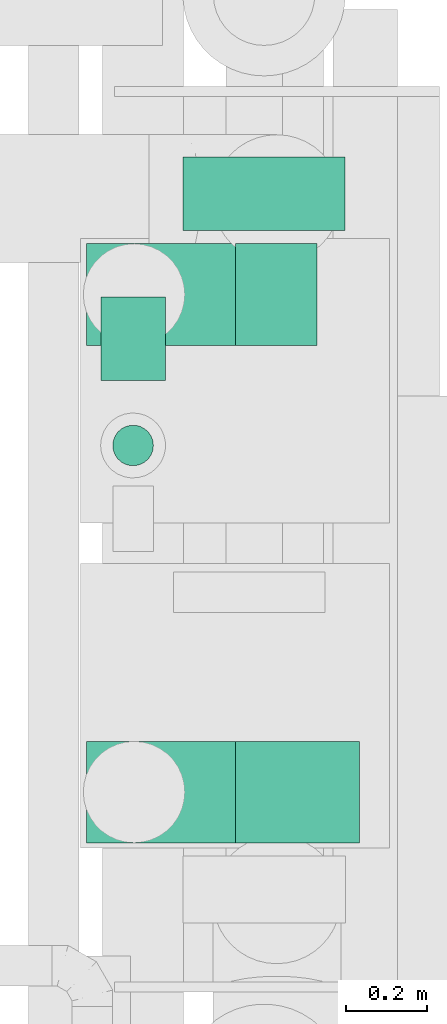
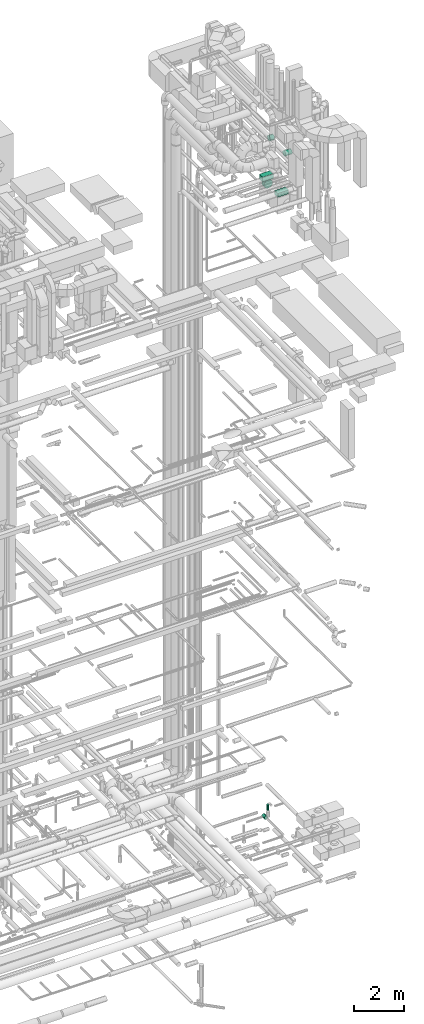
# One storey, part 310 of 337: 7 flow segments.
"""IFC2X3 building model written with IfcOpenShell, lengths in millimetres."""

from ifc_helpers import new_model, entity, si_unit, converted_unit, derived_unit, direction, frame, origin, origin_2d_with_axis, place, context, subcontext, project, spatial, rectangle, circle, extrude, type_object, element, save


model = new_model("IFC2X3")

# Units and contexts
model_context = context("Model", 3, precision=0.01, world=origin(), true_north=direction((6.12303176911189e-17, 1.0)))
body_context = subcontext(model_context, "Body", "Model", "MODEL_VIEW")
ifc_project = project(units=[si_unit("LENGTHUNIT", "METRE", prefix="MILLI"), si_unit("AREAUNIT", "SQUARE_METRE"), si_unit("VOLUMEUNIT", "CUBIC_METRE"), converted_unit("PLANEANGLEUNIT", "DEGREE", entity("IfcRatioMeasure", 0.0174532925199433), si_unit("PLANEANGLEUNIT", "RADIAN"), dimensions=[0, 0, 0, 0, 0, 0, 0]), si_unit("MASSUNIT", "GRAM", prefix="KILO"), derived_unit("MASSDENSITYUNIT", [(si_unit("MASSUNIT", "GRAM", prefix="KILO"), 1), (si_unit("LENGTHUNIT", "METRE"), -3)]), derived_unit("MOMENTOFINERTIAUNIT", [(si_unit("LENGTHUNIT", "METRE"), 4)]), si_unit("TIMEUNIT", "SECOND"), si_unit("FREQUENCYUNIT", "HERTZ"), si_unit("THERMODYNAMICTEMPERATUREUNIT", "DEGREE_CELSIUS"), derived_unit("THERMALTRANSMITTANCEUNIT", [(si_unit("MASSUNIT", "GRAM", prefix="KILO"), 1), (si_unit("THERMODYNAMICTEMPERATUREUNIT", "KELVIN"), -1), (si_unit("TIMEUNIT", "SECOND"), -3)]), derived_unit("VOLUMETRICFLOWRATEUNIT", [(si_unit("LENGTHUNIT", "METRE"), 3), (si_unit("TIMEUNIT", "SECOND"), -1)]), derived_unit("MASSFLOWRATEUNIT", [(si_unit("MASSUNIT", "GRAM", prefix="KILO"), 1), (si_unit("TIMEUNIT", "SECOND"), -1)]), derived_unit("ROTATIONALFREQUENCYUNIT", [(si_unit("TIMEUNIT", "SECOND"), -1)]), si_unit("ELECTRICCURRENTUNIT", "AMPERE"), si_unit("ELECTRICVOLTAGEUNIT", "VOLT"), si_unit("POWERUNIT", "WATT"), si_unit("FORCEUNIT", "NEWTON", prefix="KILO"), si_unit("ILLUMINANCEUNIT", "LUX"), si_unit("LUMINOUSFLUXUNIT", "LUMEN"), si_unit("LUMINOUSINTENSITYUNIT", "CANDELA"), derived_unit("USERDEFINED", [(si_unit("MASSUNIT", "GRAM", prefix="KILO"), -1), (si_unit("LENGTHUNIT", "METRE"), -2), (si_unit("TIMEUNIT", "SECOND"), 3), (si_unit("LUMINOUSFLUXUNIT", "LUMEN"), 1)]), derived_unit("LINEARVELOCITYUNIT", [(si_unit("LENGTHUNIT", "METRE"), 1), (si_unit("TIMEUNIT", "SECOND"), -1)]), si_unit("PRESSUREUNIT", "PASCAL"), derived_unit("USERDEFINED", [(si_unit("LENGTHUNIT", "METRE"), -2), (si_unit("MASSUNIT", "GRAM", prefix="KILO"), 1), (si_unit("TIMEUNIT", "SECOND"), -2)]), derived_unit("LINEARFORCEUNIT", [(si_unit("MASSUNIT", "GRAM", prefix="KILO"), 1), (si_unit("LENGTHUNIT", "METRE"), 1), (si_unit("TIMEUNIT", "SECOND"), -2), (si_unit("LENGTHUNIT", "METRE"), -1)]), derived_unit("PLANARFORCEUNIT", [(si_unit("MASSUNIT", "GRAM", prefix="KILO"), 1), (si_unit("LENGTHUNIT", "METRE"), 1), (si_unit("TIMEUNIT", "SECOND"), -2), (si_unit("LENGTHUNIT", "METRE"), -2)])], contexts=[model_context])

# Site, building, storey
site_placement = place(None, origin())
site = spatial("IfcSite", under=ifc_project, at=site_placement, CompositionType="ELEMENT")
building_placement = place(site_placement, origin())
building = spatial("IfcBuilding", under=site, at=building_placement, CompositionType="ELEMENT")
storey_placement = place(building_placement, origin())
storey = spatial("IfcBuildingStorey", under=building, at=storey_placement, CompositionType="ELEMENT", Elevation=0.0)

# Flow segments
duct_segment_type_1 = type_object("IfcDuctSegmentType", PredefinedType="NOTDEFINED")
flow_segment_1_placement = place(storey_placement, frame((72274.97, 11857.7, 29270.0)))
element("IfcFlowSegment", 1, at=flow_segment_1_placement, inside=storey, type_object=duct_segment_type_1, context=body_context, shape_type="SweptSolid", body=[
    extrude(rectangle(XDim=500.000000000008, YDim=249.999999999999, at=origin_2d_with_axis()), frame((250.0, 125.0, 0.0)), (0.0, 0.0, 1.0), 179.999999999989),
])
flow_segment_2_placement = place(storey_placement, frame((72274.97, 13082.7, 29270.0)))
element("IfcFlowSegment", 2, at=flow_segment_2_placement, inside=storey, type_object=duct_segment_type_1, context=body_context, shape_type="SweptSolid", body=[
    extrude(rectangle(XDim=249.999999999999, YDim=499.999999999999, at=origin_2d_with_axis()), frame((250.0, 125.0, 0.0), z_axis=(0.0, 0.0, 1.0), x_axis=(0.0, -1.0, 0.0)), (0.0, 0.0, 1.0), 229.999999999891),
])
duct_segment_type_2 = type_object("IfcDuctSegmentType", PredefinedType="NOTDEFINED")
flow_segment_3_placement = place(storey_placement, frame((72337.72, 12784.4, -1166.0)))
element("IfcFlowSegment", 3, at=flow_segment_3_placement, inside=storey, type_object=duct_segment_type_2, context=body_context, shape_type="SweptSolid", body=[
    extrude(circle(Radius=50.0, at=origin_2d_with_axis()), frame((51.6, 51.6, 0.0), z_axis=(0.0, 0.0, 1.0), x_axis=(-1.0, 0.0, 0.0)), (0.0, 0.0, 1.0), 266.000000000001),
])
flow_segment_4_placement = place(storey_placement, frame((72307.72, 12996.0, -1734.6)))
element("IfcFlowSegment", 4, at=flow_segment_4_placement, inside=storey, type_object=duct_segment_type_2, context=body_context, shape_type="SweptSolid", body=[
    extrude(circle(Radius=80.0, at=origin_2d_with_axis()), frame((81.6, 0.0, 81.6), z_axis=(0.0, 1.0, 0.0), x_axis=(1.0, 0.0, 0.0)), (0.0, 0.0, 1.0), 205.000000000005),
])
flow_segment_5_placement = place(storey_placement, frame((72641.81, 13081.1, 31073.4)))
element("IfcFlowSegment", 5, at=flow_segment_5_placement, inside=storey, type_object=duct_segment_type_2, context=body_context, shape_type="SweptSolid", body=[
    extrude(circle(Radius=125.0, at=origin_2d_with_axis()), frame((0.0, 126.6, 126.6), z_axis=(1.0, 0.0, 0.0), x_axis=(0.0, -1.0, 0.0)), (0.0, 0.0, 1.0), 200.000327551001),
])
flow_segment_6_placement = place(storey_placement, frame((72641.9, 11856.1, 31073.33)))
element("IfcFlowSegment", 6, at=flow_segment_6_placement, inside=storey, type_object=duct_segment_type_2, context=body_context, shape_type="SweptSolid", body=[
    extrude(circle(Radius=125.0, at=origin_2d_with_axis()), frame((0.09, 126.6, 126.81), z_axis=(0.999999752694756, 0.0, -0.000703285451172731), x_axis=(0.0, -1.0, 0.0)), (0.0, 0.0, 1.0), 304.824376613845),
])
flow_segment_7_placement = place(storey_placement, frame((72510.22, 13365.08, 28648.4)))
element("IfcFlowSegment", 7, at=flow_segment_7_placement, inside=storey, type_object=duct_segment_type_2, context=body_context, shape_type="SweptSolid", body=[
    extrude(circle(Radius=200.0, at=origin_2d_with_axis()), frame((201.6, 0.0, 201.6), z_axis=(0.0, 1.0, 0.0), x_axis=(-1.0, 0.0, 0.0)), (0.0, 0.0, 1.0), 180.778444822543),
])

save(model, "model.ifc")
